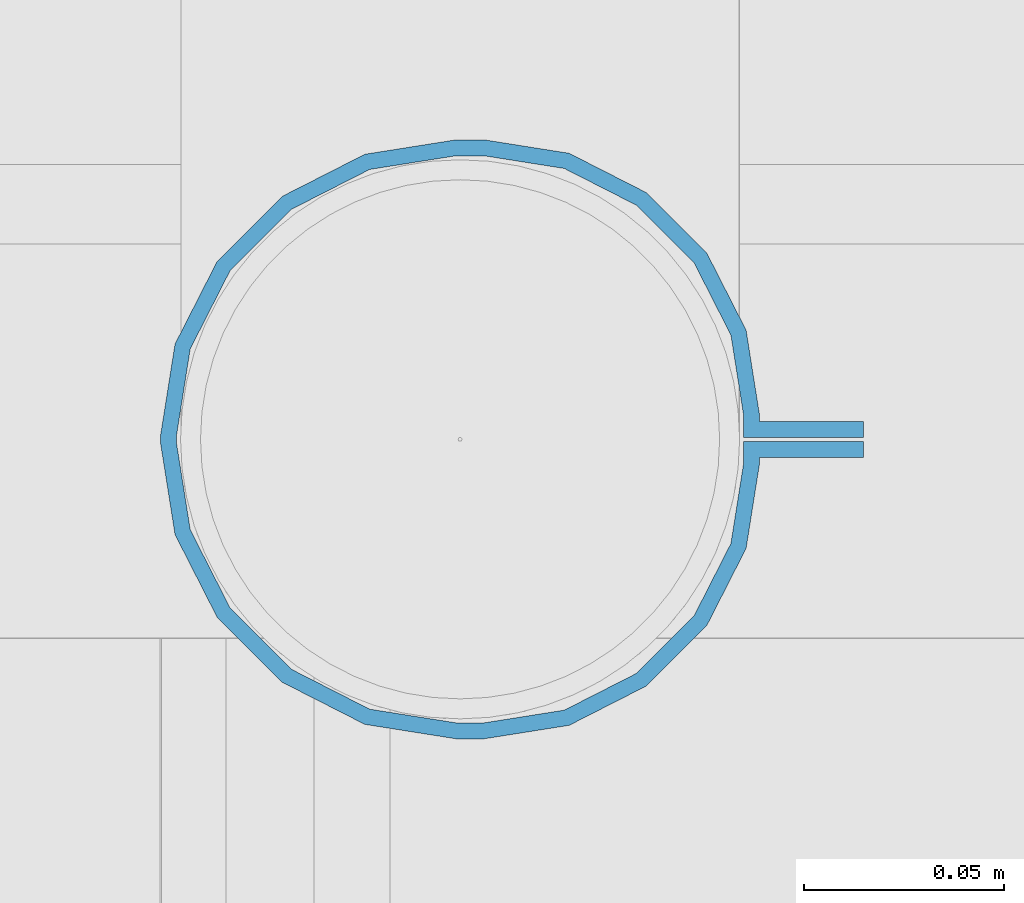
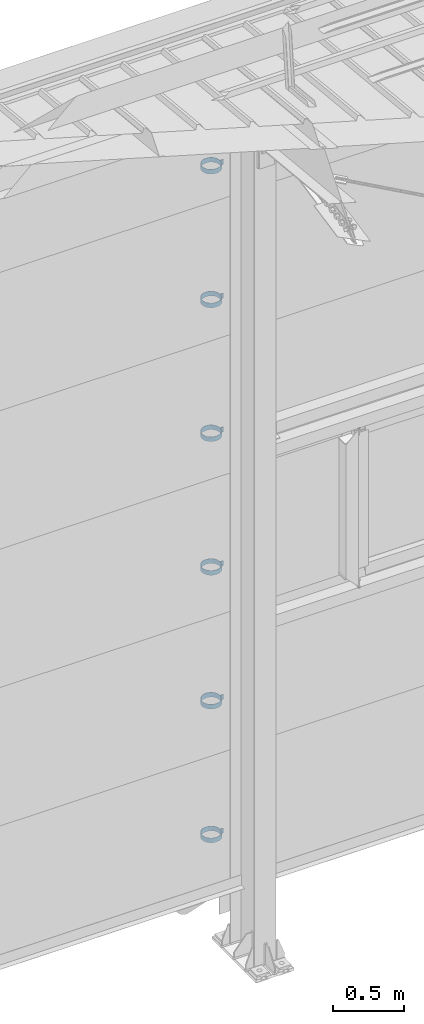
# One storey, part 303 of 709: 6 beams, 6 elements without a shape of their own.
"""IFC4 building model written with IfcOpenShell, lengths in millimetres."""

from ifc_helpers import new_model, si_unit, direction, frame, origin_with_axes, place, context, subcontext, project, spatial, polygons, material, element, aggregate, save


model = new_model("IFC4")

# Units and contexts
model_context = context("Model", 3, precision=0.2, world=origin_with_axes(), true_north=direction((0.0, 1.0)))
body_context = subcontext(model_context, "Body", "Model", "MODEL_VIEW")
ifc_project = project(units=[si_unit("LENGTHUNIT", "METRE", prefix="MILLI"), si_unit("AREAUNIT", "SQUARE_METRE"), si_unit("VOLUMEUNIT", "CUBIC_METRE"), si_unit("MASSUNIT", "GRAM", prefix="KILO"), si_unit("TIMEUNIT", "SECOND"), si_unit("PLANEANGLEUNIT", "RADIAN"), si_unit("SOLIDANGLEUNIT", "STERADIAN"), si_unit("THERMODYNAMICTEMPERATUREUNIT", "DEGREE_CELSIUS"), si_unit("LUMINOUSINTENSITYUNIT", "LUMEN")], contexts=[model_context])

# Site, building, storey
site_placement = place(None, origin_with_axes())
site = spatial("IfcSite", under=ifc_project, at=site_placement, CompositionType="ELEMENT")
building_placement = place(site_placement, origin_with_axes())
building = spatial("IfcBuilding", under=site, at=building_placement, Name="Undefined", CompositionType="ELEMENT")
storey_placement = place(building_placement, origin_with_axes())
storey = spatial("IfcBuildingStorey", under=building, at=storey_placement, Name="Undefined", CompositionType="ELEMENT", Elevation=0.0)

# Assembly, beam
assembly_1_placement = place(storey_placement, frame((4101.0, 22422.5, 6226.92297), z_axis=(0.0, 1.0, 0.0), x_axis=(-1.0, 0.0, 0.0)))
assembly_1 = element("IfcElementAssembly", 1, at=assembly_1_placement, inside=storey)
ifc_material = material(Name="Steel_Undefined", Category="STEEL")
beam_1_placement = place(assembly_1_placement, origin_with_axes())
beam_1 = element("IfcBeam", 2, at=beam_1_placement, material=ifc_material, ObjectType="616", context=body_context, shape_type="Tessellation", body=[
    polygons([(0.0, -20.0, 2.0), (0.0, 20.0, 2.0), (0.0, 20.0, -2.0), (0.0, -20.0, -2.0), (30.0, 20.0, -2.0), (30.0, -20.0, -2.0), (26.0, -20.0, 2.0), (26.0, 20.0, 2.0), (30.0, 20.0, 3.5), (30.0, -20.0, 3.5), (26.0, -20.0, 3.5), (26.0, 20.0, 3.5), (33.18133, 20.0, 23.5861), (33.18133, -20.0, 23.5861), (29.3771, -20.0, 24.82217), (29.3771, 20.0, 24.82217), (39.17783, -20.0, 44.05718), (39.17783, 20.0, 44.05718), (42.4139, 20.0, 41.70604), (42.4139, -20.0, 41.70604), (54.44282, -20.0, 59.32217), (54.44282, 20.0, 59.32217), (56.79396, 20.0, 56.0861), (56.79396, -20.0, 56.0861), (73.67783, -20.0, 69.1229), (73.67783, 20.0, 69.1229), (74.9139, 20.0, 65.31867), (74.9139, -20.0, 65.31867), (95.0, -20.0, 72.5), (95.0, 20.0, 72.5), (95.0, 20.0, 68.5), (95.0, -20.0, 68.5), (102.0, 20.0, 68.5), (102.0, -20.0, 68.5), (102.0, -20.0, 72.5), (102.0, 20.0, 72.5), (123.63119, 20.0, 65.07396), (123.63119, -20.0, 65.07396), (124.86726, -20.0, 68.87818), (124.86726, 20.0, 68.87818), (145.49611, -20.0, 58.36726), (145.49611, 20.0, 58.36726), (143.14497, 20.0, 55.13119), (143.14497, -20.0, 55.13119), (161.86726, -20.0, 41.99611), (161.86726, 20.0, 41.99611), (158.63119, 20.0, 39.64497), (158.63119, -20.0, 39.64497), (172.37818, -20.0, 21.36726), (172.37818, 20.0, 21.36726), (168.57396, 20.0, 20.13119), (168.57396, -20.0, 20.13119), (176.0, -20.0, -1.5), (176.0, 20.0, -1.5), (172.0, 20.0, -1.5), (172.0, -20.0, -1.5), (172.0, 20.0, -3.5), (172.0, -20.0, -3.5), (176.0, -20.0, -3.5), (176.0, 20.0, -3.5), (168.57396, 20.0, -25.13119), (168.57396, -20.0, -25.13119), (172.37818, -20.0, -26.36726), (172.37818, 20.0, -26.36726), (161.86726, -20.0, -46.99611), (161.86726, 20.0, -46.99611), (158.63119, 20.0, -44.64497), (158.63119, -20.0, -44.64497), (145.49611, -20.0, -63.36726), (145.49611, 20.0, -63.36726), (143.14497, 20.0, -60.13119), (143.14497, -20.0, -60.13119), (124.86726, -20.0, -73.87818), (124.86726, 20.0, -73.87818), (123.63119, 20.0, -70.07396), (123.63119, -20.0, -70.07396), (102.0, -20.0, -77.5), (102.0, 20.0, -77.5), (102.0, 20.0, -73.5), (102.0, -20.0, -73.5), (95.0, 20.0, -73.5), (95.0, -20.0, -73.5), (95.0, -20.0, -77.5), (95.0, 20.0, -77.5), (74.9139, 20.0, -70.31867), (74.9139, -20.0, -70.31867), (73.67783, -20.0, -74.1229), (73.67783, 20.0, -74.1229), (54.44282, -20.0, -64.32217), (54.44282, 20.0, -64.32217), (56.79396, 20.0, -61.0861), (56.79396, -20.0, -61.0861), (39.17783, -20.0, -49.05718), (39.17783, 20.0, -49.05718), (42.4139, 20.0, -46.70604), (42.4139, -20.0, -46.70604), (29.3771, -20.0, -29.82217), (29.3771, 20.0, -29.82217), (33.18133, 20.0, -28.5861), (33.18133, -20.0, -28.5861), (26.0, -20.0, -8.5), (26.0, 20.0, -8.5), (30.0, 20.0, -8.5), (30.0, -20.0, -8.5), (30.0, 20.0, -3.0), (30.0, -20.0, -3.0), (26.0, -20.0, -7.0), (26.0, 20.0, -7.0), (0.0, 20.0, -3.0), (0.0, -20.0, -3.0), (0.0, 20.0, -7.0), (0.0, -20.0, -7.0)], [[[1, 2, 3, 4]], [[4, 3, 5, 6]], [[2, 1, 7, 8]], [[6, 5, 9, 10]], [[8, 7, 11, 12]], [[10, 9, 13, 14]], [[12, 11, 15, 16]], [[15, 17, 18, 16]], [[13, 19, 20, 14]], [[17, 21, 22, 18]], [[19, 23, 24, 20]], [[21, 25, 26, 22]], [[23, 27, 28, 24]], [[25, 29, 30, 26]], [[27, 31, 32, 28]], [[32, 31, 33, 34]], [[30, 29, 35, 36]], [[34, 33, 37, 38]], [[36, 35, 39, 40]], [[39, 41, 42, 40]], [[37, 43, 44, 38]], [[41, 45, 46, 42]], [[43, 47, 48, 44]], [[45, 49, 50, 46]], [[47, 51, 52, 48]], [[49, 53, 54, 50]], [[51, 55, 56, 52]], [[56, 55, 57, 58]], [[54, 53, 59, 60]], [[58, 57, 61, 62]], [[60, 59, 63, 64]], [[63, 65, 66, 64]], [[61, 67, 68, 62]], [[65, 69, 70, 66]], [[67, 71, 72, 68]], [[69, 73, 74, 70]], [[71, 75, 76, 72]], [[73, 77, 78, 74]], [[75, 79, 80, 76]], [[80, 79, 81, 82]], [[78, 77, 83, 84]], [[82, 81, 85, 86]], [[84, 83, 87, 88]], [[87, 89, 90, 88]], [[85, 91, 92, 86]], [[89, 93, 94, 90]], [[91, 95, 96, 92]], [[93, 97, 98, 94]], [[95, 99, 100, 96]], [[97, 101, 102, 98]], [[99, 103, 104, 100]], [[104, 103, 105, 106]], [[102, 101, 107, 108]], [[106, 105, 109, 110]], [[105, 103, 99, 95, 91, 85, 81, 79, 75, 71, 67, 61, 57, 55, 51, 47, 43, 37, 33, 31, 27, 23, 19, 13, 9, 5, 3, 2, 8, 12, 16, 18, 22, 26, 30, 36, 40, 42, 46, 50, 54, 60, 64, 66, 70, 74, 78, 84, 88, 90, 94, 98, 102, 108, 111, 109]], [[108, 107, 112, 111]], [[107, 101, 97, 93, 89, 87, 83, 77, 73, 69, 65, 63, 59, 53, 49, 45, 41, 39, 35, 29, 25, 21, 17, 15, 11, 7, 1, 4, 6, 10, 14, 20, 24, 28, 32, 34, 38, 44, 48, 52, 56, 58, 62, 68, 72, 76, 80, 82, 86, 92, 96, 100, 104, 106, 110, 112]], [[111, 112, 110, 109]]], closed=True),
])
aggregate(assembly_1, [beam_1])

assembly_2_placement = place(storey_placement, frame((4101.0, 22422.5, 5076.92297), z_axis=(0.0, 1.0, 0.0), x_axis=(-1.0, 0.0, 0.0)))
assembly_2 = element("IfcElementAssembly", 3, at=assembly_2_placement, inside=storey)
beam_2_placement = place(assembly_2_placement, origin_with_axes())
beam_2 = element("IfcBeam", 4, at=beam_2_placement, material=ifc_material, ObjectType="616", context=body_context, shape_type="Tessellation", body=[
    polygons([(0.0, -20.0, 2.0), (0.0, 20.0, 2.0), (0.0, 20.0, -2.0), (0.0, -20.0, -2.0), (30.0, 20.0, -2.0), (30.0, -20.0, -2.0), (26.0, -20.0, 2.0), (26.0, 20.0, 2.0), (30.0, 20.0, 3.5), (30.0, -20.0, 3.5), (26.0, -20.0, 3.5), (26.0, 20.0, 3.5), (33.18133, 20.0, 23.5861), (33.18133, -20.0, 23.5861), (29.3771, -20.0, 24.82217), (29.3771, 20.0, 24.82217), (39.17783, -20.0, 44.05718), (39.17783, 20.0, 44.05718), (42.4139, 20.0, 41.70604), (42.4139, -20.0, 41.70604), (54.44282, -20.0, 59.32217), (54.44282, 20.0, 59.32217), (56.79396, 20.0, 56.0861), (56.79396, -20.0, 56.0861), (73.67783, -20.0, 69.1229), (73.67783, 20.0, 69.1229), (74.9139, 20.0, 65.31867), (74.9139, -20.0, 65.31867), (95.0, -20.0, 72.5), (95.0, 20.0, 72.5), (95.0, 20.0, 68.5), (95.0, -20.0, 68.5), (102.0, 20.0, 68.5), (102.0, -20.0, 68.5), (102.0, -20.0, 72.5), (102.0, 20.0, 72.5), (123.63119, 20.0, 65.07396), (123.63119, -20.0, 65.07396), (124.86726, -20.0, 68.87818), (124.86726, 20.0, 68.87818), (145.49611, -20.0, 58.36726), (145.49611, 20.0, 58.36726), (143.14497, 20.0, 55.13119), (143.14497, -20.0, 55.13119), (161.86726, -20.0, 41.99611), (161.86726, 20.0, 41.99611), (158.63119, 20.0, 39.64497), (158.63119, -20.0, 39.64497), (172.37818, -20.0, 21.36726), (172.37818, 20.0, 21.36726), (168.57396, 20.0, 20.13119), (168.57396, -20.0, 20.13119), (176.0, -20.0, -1.5), (176.0, 20.0, -1.5), (172.0, 20.0, -1.5), (172.0, -20.0, -1.5), (172.0, 20.0, -3.5), (172.0, -20.0, -3.5), (176.0, -20.0, -3.5), (176.0, 20.0, -3.5), (168.57396, 20.0, -25.13119), (168.57396, -20.0, -25.13119), (172.37818, -20.0, -26.36726), (172.37818, 20.0, -26.36726), (161.86726, -20.0, -46.99611), (161.86726, 20.0, -46.99611), (158.63119, 20.0, -44.64497), (158.63119, -20.0, -44.64497), (145.49611, -20.0, -63.36726), (145.49611, 20.0, -63.36726), (143.14497, 20.0, -60.13119), (143.14497, -20.0, -60.13119), (124.86726, -20.0, -73.87818), (124.86726, 20.0, -73.87818), (123.63119, 20.0, -70.07396), (123.63119, -20.0, -70.07396), (102.0, -20.0, -77.5), (102.0, 20.0, -77.5), (102.0, 20.0, -73.5), (102.0, -20.0, -73.5), (95.0, 20.0, -73.5), (95.0, -20.0, -73.5), (95.0, -20.0, -77.5), (95.0, 20.0, -77.5), (74.9139, 20.0, -70.31867), (74.9139, -20.0, -70.31867), (73.67783, -20.0, -74.1229), (73.67783, 20.0, -74.1229), (54.44282, -20.0, -64.32217), (54.44282, 20.0, -64.32217), (56.79396, 20.0, -61.0861), (56.79396, -20.0, -61.0861), (39.17783, -20.0, -49.05718), (39.17783, 20.0, -49.05718), (42.4139, 20.0, -46.70604), (42.4139, -20.0, -46.70604), (29.3771, -20.0, -29.82217), (29.3771, 20.0, -29.82217), (33.18133, 20.0, -28.5861), (33.18133, -20.0, -28.5861), (26.0, -20.0, -8.5), (26.0, 20.0, -8.5), (30.0, 20.0, -8.5), (30.0, -20.0, -8.5), (30.0, 20.0, -3.0), (30.0, -20.0, -3.0), (26.0, -20.0, -7.0), (26.0, 20.0, -7.0), (0.0, 20.0, -3.0), (0.0, -20.0, -3.0), (0.0, 20.0, -7.0), (0.0, -20.0, -7.0)], [[[1, 2, 3, 4]], [[4, 3, 5, 6]], [[2, 1, 7, 8]], [[6, 5, 9, 10]], [[8, 7, 11, 12]], [[10, 9, 13, 14]], [[12, 11, 15, 16]], [[15, 17, 18, 16]], [[13, 19, 20, 14]], [[17, 21, 22, 18]], [[19, 23, 24, 20]], [[21, 25, 26, 22]], [[23, 27, 28, 24]], [[25, 29, 30, 26]], [[27, 31, 32, 28]], [[32, 31, 33, 34]], [[30, 29, 35, 36]], [[34, 33, 37, 38]], [[36, 35, 39, 40]], [[39, 41, 42, 40]], [[37, 43, 44, 38]], [[41, 45, 46, 42]], [[43, 47, 48, 44]], [[45, 49, 50, 46]], [[47, 51, 52, 48]], [[49, 53, 54, 50]], [[51, 55, 56, 52]], [[56, 55, 57, 58]], [[54, 53, 59, 60]], [[58, 57, 61, 62]], [[60, 59, 63, 64]], [[63, 65, 66, 64]], [[61, 67, 68, 62]], [[65, 69, 70, 66]], [[67, 71, 72, 68]], [[69, 73, 74, 70]], [[71, 75, 76, 72]], [[73, 77, 78, 74]], [[75, 79, 80, 76]], [[80, 79, 81, 82]], [[78, 77, 83, 84]], [[82, 81, 85, 86]], [[84, 83, 87, 88]], [[87, 89, 90, 88]], [[85, 91, 92, 86]], [[89, 93, 94, 90]], [[91, 95, 96, 92]], [[93, 97, 98, 94]], [[95, 99, 100, 96]], [[97, 101, 102, 98]], [[99, 103, 104, 100]], [[104, 103, 105, 106]], [[102, 101, 107, 108]], [[106, 105, 109, 110]], [[105, 103, 99, 95, 91, 85, 81, 79, 75, 71, 67, 61, 57, 55, 51, 47, 43, 37, 33, 31, 27, 23, 19, 13, 9, 5, 3, 2, 8, 12, 16, 18, 22, 26, 30, 36, 40, 42, 46, 50, 54, 60, 64, 66, 70, 74, 78, 84, 88, 90, 94, 98, 102, 108, 111, 109]], [[108, 107, 112, 111]], [[107, 101, 97, 93, 89, 87, 83, 77, 73, 69, 65, 63, 59, 53, 49, 45, 41, 39, 35, 29, 25, 21, 17, 15, 11, 7, 1, 4, 6, 10, 14, 20, 24, 28, 32, 34, 38, 44, 48, 52, 56, 58, 62, 68, 72, 76, 80, 82, 86, 92, 96, 100, 104, 106, 110, 112]], [[111, 112, 110, 109]]], closed=True),
])
aggregate(assembly_2, [beam_2])

assembly_3_placement = place(storey_placement, frame((4101.0, 22422.5, 3926.92297), z_axis=(0.0, 1.0, 0.0), x_axis=(-1.0, 0.0, 0.0)))
assembly_3 = element("IfcElementAssembly", 5, at=assembly_3_placement, inside=storey)
beam_3_placement = place(assembly_3_placement, origin_with_axes())
beam_3 = element("IfcBeam", 6, at=beam_3_placement, material=ifc_material, ObjectType="616", context=body_context, shape_type="Tessellation", body=[
    polygons([(0.0, -20.0, 2.0), (0.0, 20.0, 2.0), (0.0, 20.0, -2.0), (0.0, -20.0, -2.0), (30.0, 20.0, -2.0), (30.0, -20.0, -2.0), (26.0, -20.0, 2.0), (26.0, 20.0, 2.0), (30.0, 20.0, 3.5), (30.0, -20.0, 3.5), (26.0, -20.0, 3.5), (26.0, 20.0, 3.5), (33.18133, 20.0, 23.5861), (33.18133, -20.0, 23.5861), (29.3771, -20.0, 24.82217), (29.3771, 20.0, 24.82217), (39.17783, -20.0, 44.05718), (39.17783, 20.0, 44.05718), (42.4139, 20.0, 41.70604), (42.4139, -20.0, 41.70604), (54.44282, -20.0, 59.32217), (54.44282, 20.0, 59.32217), (56.79396, 20.0, 56.0861), (56.79396, -20.0, 56.0861), (73.67783, -20.0, 69.1229), (73.67783, 20.0, 69.1229), (74.9139, 20.0, 65.31867), (74.9139, -20.0, 65.31867), (95.0, -20.0, 72.5), (95.0, 20.0, 72.5), (95.0, 20.0, 68.5), (95.0, -20.0, 68.5), (102.0, 20.0, 68.5), (102.0, -20.0, 68.5), (102.0, -20.0, 72.5), (102.0, 20.0, 72.5), (123.63119, 20.0, 65.07396), (123.63119, -20.0, 65.07396), (124.86726, -20.0, 68.87818), (124.86726, 20.0, 68.87818), (145.49611, -20.0, 58.36726), (145.49611, 20.0, 58.36726), (143.14497, 20.0, 55.13119), (143.14497, -20.0, 55.13119), (161.86726, -20.0, 41.99611), (161.86726, 20.0, 41.99611), (158.63119, 20.0, 39.64497), (158.63119, -20.0, 39.64497), (172.37818, -20.0, 21.36726), (172.37818, 20.0, 21.36726), (168.57396, 20.0, 20.13119), (168.57396, -20.0, 20.13119), (176.0, -20.0, -1.5), (176.0, 20.0, -1.5), (172.0, 20.0, -1.5), (172.0, -20.0, -1.5), (172.0, 20.0, -3.5), (172.0, -20.0, -3.5), (176.0, -20.0, -3.5), (176.0, 20.0, -3.5), (168.57396, 20.0, -25.13119), (168.57396, -20.0, -25.13119), (172.37818, -20.0, -26.36726), (172.37818, 20.0, -26.36726), (161.86726, -20.0, -46.99611), (161.86726, 20.0, -46.99611), (158.63119, 20.0, -44.64497), (158.63119, -20.0, -44.64497), (145.49611, -20.0, -63.36726), (145.49611, 20.0, -63.36726), (143.14497, 20.0, -60.13119), (143.14497, -20.0, -60.13119), (124.86726, -20.0, -73.87818), (124.86726, 20.0, -73.87818), (123.63119, 20.0, -70.07396), (123.63119, -20.0, -70.07396), (102.0, -20.0, -77.5), (102.0, 20.0, -77.5), (102.0, 20.0, -73.5), (102.0, -20.0, -73.5), (95.0, 20.0, -73.5), (95.0, -20.0, -73.5), (95.0, -20.0, -77.5), (95.0, 20.0, -77.5), (74.9139, 20.0, -70.31867), (74.9139, -20.0, -70.31867), (73.67783, -20.0, -74.1229), (73.67783, 20.0, -74.1229), (54.44282, -20.0, -64.32217), (54.44282, 20.0, -64.32217), (56.79396, 20.0, -61.0861), (56.79396, -20.0, -61.0861), (39.17783, -20.0, -49.05718), (39.17783, 20.0, -49.05718), (42.4139, 20.0, -46.70604), (42.4139, -20.0, -46.70604), (29.3771, -20.0, -29.82217), (29.3771, 20.0, -29.82217), (33.18133, 20.0, -28.5861), (33.18133, -20.0, -28.5861), (26.0, -20.0, -8.5), (26.0, 20.0, -8.5), (30.0, 20.0, -8.5), (30.0, -20.0, -8.5), (30.0, 20.0, -3.0), (30.0, -20.0, -3.0), (26.0, -20.0, -7.0), (26.0, 20.0, -7.0), (0.0, 20.0, -3.0), (0.0, -20.0, -3.0), (0.0, 20.0, -7.0), (0.0, -20.0, -7.0)], [[[1, 2, 3, 4]], [[4, 3, 5, 6]], [[2, 1, 7, 8]], [[6, 5, 9, 10]], [[8, 7, 11, 12]], [[10, 9, 13, 14]], [[12, 11, 15, 16]], [[15, 17, 18, 16]], [[13, 19, 20, 14]], [[17, 21, 22, 18]], [[19, 23, 24, 20]], [[21, 25, 26, 22]], [[23, 27, 28, 24]], [[25, 29, 30, 26]], [[27, 31, 32, 28]], [[32, 31, 33, 34]], [[30, 29, 35, 36]], [[34, 33, 37, 38]], [[36, 35, 39, 40]], [[39, 41, 42, 40]], [[37, 43, 44, 38]], [[41, 45, 46, 42]], [[43, 47, 48, 44]], [[45, 49, 50, 46]], [[47, 51, 52, 48]], [[49, 53, 54, 50]], [[51, 55, 56, 52]], [[56, 55, 57, 58]], [[54, 53, 59, 60]], [[58, 57, 61, 62]], [[60, 59, 63, 64]], [[63, 65, 66, 64]], [[61, 67, 68, 62]], [[65, 69, 70, 66]], [[67, 71, 72, 68]], [[69, 73, 74, 70]], [[71, 75, 76, 72]], [[73, 77, 78, 74]], [[75, 79, 80, 76]], [[80, 79, 81, 82]], [[78, 77, 83, 84]], [[82, 81, 85, 86]], [[84, 83, 87, 88]], [[87, 89, 90, 88]], [[85, 91, 92, 86]], [[89, 93, 94, 90]], [[91, 95, 96, 92]], [[93, 97, 98, 94]], [[95, 99, 100, 96]], [[97, 101, 102, 98]], [[99, 103, 104, 100]], [[104, 103, 105, 106]], [[102, 101, 107, 108]], [[106, 105, 109, 110]], [[105, 103, 99, 95, 91, 85, 81, 79, 75, 71, 67, 61, 57, 55, 51, 47, 43, 37, 33, 31, 27, 23, 19, 13, 9, 5, 3, 2, 8, 12, 16, 18, 22, 26, 30, 36, 40, 42, 46, 50, 54, 60, 64, 66, 70, 74, 78, 84, 88, 90, 94, 98, 102, 108, 111, 109]], [[108, 107, 112, 111]], [[107, 101, 97, 93, 89, 87, 83, 77, 73, 69, 65, 63, 59, 53, 49, 45, 41, 39, 35, 29, 25, 21, 17, 15, 11, 7, 1, 4, 6, 10, 14, 20, 24, 28, 32, 34, 38, 44, 48, 52, 56, 58, 62, 68, 72, 76, 80, 82, 86, 92, 96, 100, 104, 106, 110, 112]], [[111, 112, 110, 109]]], closed=True),
])
aggregate(assembly_3, [beam_3])

assembly_4_placement = place(storey_placement, frame((4101.0, 22422.5, 2776.92297), z_axis=(0.0, 1.0, 0.0), x_axis=(-1.0, 0.0, 0.0)))
assembly_4 = element("IfcElementAssembly", 7, at=assembly_4_placement, inside=storey)
beam_4_placement = place(assembly_4_placement, origin_with_axes())
beam_4 = element("IfcBeam", 8, at=beam_4_placement, material=ifc_material, ObjectType="616", context=body_context, shape_type="Tessellation", body=[
    polygons([(0.0, -20.0, 2.0), (0.0, 20.0, 2.0), (0.0, 20.0, -2.0), (0.0, -20.0, -2.0), (30.0, 20.0, -2.0), (30.0, -20.0, -2.0), (26.0, -20.0, 2.0), (26.0, 20.0, 2.0), (30.0, 20.0, 3.5), (30.0, -20.0, 3.5), (26.0, -20.0, 3.5), (26.0, 20.0, 3.5), (33.18133, 20.0, 23.5861), (33.18133, -20.0, 23.5861), (29.3771, -20.0, 24.82217), (29.3771, 20.0, 24.82217), (39.17783, -20.0, 44.05718), (39.17783, 20.0, 44.05718), (42.4139, 20.0, 41.70604), (42.4139, -20.0, 41.70604), (54.44282, -20.0, 59.32217), (54.44282, 20.0, 59.32217), (56.79396, 20.0, 56.0861), (56.79396, -20.0, 56.0861), (73.67783, -20.0, 69.1229), (73.67783, 20.0, 69.1229), (74.9139, 20.0, 65.31867), (74.9139, -20.0, 65.31867), (95.0, -20.0, 72.5), (95.0, 20.0, 72.5), (95.0, 20.0, 68.5), (95.0, -20.0, 68.5), (102.0, 20.0, 68.5), (102.0, -20.0, 68.5), (102.0, -20.0, 72.5), (102.0, 20.0, 72.5), (123.63119, 20.0, 65.07396), (123.63119, -20.0, 65.07396), (124.86726, -20.0, 68.87818), (124.86726, 20.0, 68.87818), (145.49611, -20.0, 58.36726), (145.49611, 20.0, 58.36726), (143.14497, 20.0, 55.13119), (143.14497, -20.0, 55.13119), (161.86726, -20.0, 41.99611), (161.86726, 20.0, 41.99611), (158.63119, 20.0, 39.64497), (158.63119, -20.0, 39.64497), (172.37818, -20.0, 21.36726), (172.37818, 20.0, 21.36726), (168.57396, 20.0, 20.13119), (168.57396, -20.0, 20.13119), (176.0, -20.0, -1.5), (176.0, 20.0, -1.5), (172.0, 20.0, -1.5), (172.0, -20.0, -1.5), (172.0, 20.0, -3.5), (172.0, -20.0, -3.5), (176.0, -20.0, -3.5), (176.0, 20.0, -3.5), (168.57396, 20.0, -25.13119), (168.57396, -20.0, -25.13119), (172.37818, -20.0, -26.36726), (172.37818, 20.0, -26.36726), (161.86726, -20.0, -46.99611), (161.86726, 20.0, -46.99611), (158.63119, 20.0, -44.64497), (158.63119, -20.0, -44.64497), (145.49611, -20.0, -63.36726), (145.49611, 20.0, -63.36726), (143.14497, 20.0, -60.13119), (143.14497, -20.0, -60.13119), (124.86726, -20.0, -73.87818), (124.86726, 20.0, -73.87818), (123.63119, 20.0, -70.07396), (123.63119, -20.0, -70.07396), (102.0, -20.0, -77.5), (102.0, 20.0, -77.5), (102.0, 20.0, -73.5), (102.0, -20.0, -73.5), (95.0, 20.0, -73.5), (95.0, -20.0, -73.5), (95.0, -20.0, -77.5), (95.0, 20.0, -77.5), (74.9139, 20.0, -70.31867), (74.9139, -20.0, -70.31867), (73.67783, -20.0, -74.1229), (73.67783, 20.0, -74.1229), (54.44282, -20.0, -64.32217), (54.44282, 20.0, -64.32217), (56.79396, 20.0, -61.0861), (56.79396, -20.0, -61.0861), (39.17783, -20.0, -49.05718), (39.17783, 20.0, -49.05718), (42.4139, 20.0, -46.70604), (42.4139, -20.0, -46.70604), (29.3771, -20.0, -29.82217), (29.3771, 20.0, -29.82217), (33.18133, 20.0, -28.5861), (33.18133, -20.0, -28.5861), (26.0, -20.0, -8.5), (26.0, 20.0, -8.5), (30.0, 20.0, -8.5), (30.0, -20.0, -8.5), (30.0, 20.0, -3.0), (30.0, -20.0, -3.0), (26.0, -20.0, -7.0), (26.0, 20.0, -7.0), (0.0, 20.0, -3.0), (0.0, -20.0, -3.0), (0.0, 20.0, -7.0), (0.0, -20.0, -7.0)], [[[1, 2, 3, 4]], [[4, 3, 5, 6]], [[2, 1, 7, 8]], [[6, 5, 9, 10]], [[8, 7, 11, 12]], [[10, 9, 13, 14]], [[12, 11, 15, 16]], [[15, 17, 18, 16]], [[13, 19, 20, 14]], [[17, 21, 22, 18]], [[19, 23, 24, 20]], [[21, 25, 26, 22]], [[23, 27, 28, 24]], [[25, 29, 30, 26]], [[27, 31, 32, 28]], [[32, 31, 33, 34]], [[30, 29, 35, 36]], [[34, 33, 37, 38]], [[36, 35, 39, 40]], [[39, 41, 42, 40]], [[37, 43, 44, 38]], [[41, 45, 46, 42]], [[43, 47, 48, 44]], [[45, 49, 50, 46]], [[47, 51, 52, 48]], [[49, 53, 54, 50]], [[51, 55, 56, 52]], [[56, 55, 57, 58]], [[54, 53, 59, 60]], [[58, 57, 61, 62]], [[60, 59, 63, 64]], [[63, 65, 66, 64]], [[61, 67, 68, 62]], [[65, 69, 70, 66]], [[67, 71, 72, 68]], [[69, 73, 74, 70]], [[71, 75, 76, 72]], [[73, 77, 78, 74]], [[75, 79, 80, 76]], [[80, 79, 81, 82]], [[78, 77, 83, 84]], [[82, 81, 85, 86]], [[84, 83, 87, 88]], [[87, 89, 90, 88]], [[85, 91, 92, 86]], [[89, 93, 94, 90]], [[91, 95, 96, 92]], [[93, 97, 98, 94]], [[95, 99, 100, 96]], [[97, 101, 102, 98]], [[99, 103, 104, 100]], [[104, 103, 105, 106]], [[102, 101, 107, 108]], [[106, 105, 109, 110]], [[105, 103, 99, 95, 91, 85, 81, 79, 75, 71, 67, 61, 57, 55, 51, 47, 43, 37, 33, 31, 27, 23, 19, 13, 9, 5, 3, 2, 8, 12, 16, 18, 22, 26, 30, 36, 40, 42, 46, 50, 54, 60, 64, 66, 70, 74, 78, 84, 88, 90, 94, 98, 102, 108, 111, 109]], [[108, 107, 112, 111]], [[107, 101, 97, 93, 89, 87, 83, 77, 73, 69, 65, 63, 59, 53, 49, 45, 41, 39, 35, 29, 25, 21, 17, 15, 11, 7, 1, 4, 6, 10, 14, 20, 24, 28, 32, 34, 38, 44, 48, 52, 56, 58, 62, 68, 72, 76, 80, 82, 86, 92, 96, 100, 104, 106, 110, 112]], [[111, 112, 110, 109]]], closed=True),
])
aggregate(assembly_4, [beam_4])

assembly_5_placement = place(storey_placement, frame((4101.0, 22422.5, 1626.92297), z_axis=(0.0, 1.0, 0.0), x_axis=(-1.0, 0.0, 0.0)))
assembly_5 = element("IfcElementAssembly", 9, at=assembly_5_placement, inside=storey)
beam_5_placement = place(assembly_5_placement, origin_with_axes())
beam_5 = element("IfcBeam", 10, at=beam_5_placement, material=ifc_material, ObjectType="616", context=body_context, shape_type="Tessellation", body=[
    polygons([(0.0, -20.0, 2.0), (0.0, 20.0, 2.0), (0.0, 20.0, -2.0), (0.0, -20.0, -2.0), (30.0, 20.0, -2.0), (30.0, -20.0, -2.0), (26.0, -20.0, 2.0), (26.0, 20.0, 2.0), (30.0, 20.0, 3.5), (30.0, -20.0, 3.5), (26.0, -20.0, 3.5), (26.0, 20.0, 3.5), (33.18133, 20.0, 23.5861), (33.18133, -20.0, 23.5861), (29.3771, -20.0, 24.82217), (29.3771, 20.0, 24.82217), (39.17783, -20.0, 44.05718), (39.17783, 20.0, 44.05718), (42.4139, 20.0, 41.70604), (42.4139, -20.0, 41.70604), (54.44282, -20.0, 59.32217), (54.44282, 20.0, 59.32217), (56.79396, 20.0, 56.0861), (56.79396, -20.0, 56.0861), (73.67783, -20.0, 69.1229), (73.67783, 20.0, 69.1229), (74.9139, 20.0, 65.31867), (74.9139, -20.0, 65.31867), (95.0, -20.0, 72.5), (95.0, 20.0, 72.5), (95.0, 20.0, 68.5), (95.0, -20.0, 68.5), (102.0, 20.0, 68.5), (102.0, -20.0, 68.5), (102.0, -20.0, 72.5), (102.0, 20.0, 72.5), (123.63119, 20.0, 65.07396), (123.63119, -20.0, 65.07396), (124.86726, -20.0, 68.87818), (124.86726, 20.0, 68.87818), (145.49611, -20.0, 58.36726), (145.49611, 20.0, 58.36726), (143.14497, 20.0, 55.13119), (143.14497, -20.0, 55.13119), (161.86726, -20.0, 41.99611), (161.86726, 20.0, 41.99611), (158.63119, 20.0, 39.64497), (158.63119, -20.0, 39.64497), (172.37818, -20.0, 21.36726), (172.37818, 20.0, 21.36726), (168.57396, 20.0, 20.13119), (168.57396, -20.0, 20.13119), (176.0, -20.0, -1.5), (176.0, 20.0, -1.5), (172.0, 20.0, -1.5), (172.0, -20.0, -1.5), (172.0, 20.0, -3.5), (172.0, -20.0, -3.5), (176.0, -20.0, -3.5), (176.0, 20.0, -3.5), (168.57396, 20.0, -25.13119), (168.57396, -20.0, -25.13119), (172.37818, -20.0, -26.36726), (172.37818, 20.0, -26.36726), (161.86726, -20.0, -46.99611), (161.86726, 20.0, -46.99611), (158.63119, 20.0, -44.64497), (158.63119, -20.0, -44.64497), (145.49611, -20.0, -63.36726), (145.49611, 20.0, -63.36726), (143.14497, 20.0, -60.13119), (143.14497, -20.0, -60.13119), (124.86726, -20.0, -73.87818), (124.86726, 20.0, -73.87818), (123.63119, 20.0, -70.07396), (123.63119, -20.0, -70.07396), (102.0, -20.0, -77.5), (102.0, 20.0, -77.5), (102.0, 20.0, -73.5), (102.0, -20.0, -73.5), (95.0, 20.0, -73.5), (95.0, -20.0, -73.5), (95.0, -20.0, -77.5), (95.0, 20.0, -77.5), (74.9139, 20.0, -70.31867), (74.9139, -20.0, -70.31867), (73.67783, -20.0, -74.1229), (73.67783, 20.0, -74.1229), (54.44282, -20.0, -64.32217), (54.44282, 20.0, -64.32217), (56.79396, 20.0, -61.0861), (56.79396, -20.0, -61.0861), (39.17783, -20.0, -49.05718), (39.17783, 20.0, -49.05718), (42.4139, 20.0, -46.70604), (42.4139, -20.0, -46.70604), (29.3771, -20.0, -29.82217), (29.3771, 20.0, -29.82217), (33.18133, 20.0, -28.5861), (33.18133, -20.0, -28.5861), (26.0, -20.0, -8.5), (26.0, 20.0, -8.5), (30.0, 20.0, -8.5), (30.0, -20.0, -8.5), (30.0, 20.0, -3.0), (30.0, -20.0, -3.0), (26.0, -20.0, -7.0), (26.0, 20.0, -7.0), (0.0, 20.0, -3.0), (0.0, -20.0, -3.0), (0.0, 20.0, -7.0), (0.0, -20.0, -7.0)], [[[1, 2, 3, 4]], [[4, 3, 5, 6]], [[2, 1, 7, 8]], [[6, 5, 9, 10]], [[8, 7, 11, 12]], [[10, 9, 13, 14]], [[12, 11, 15, 16]], [[15, 17, 18, 16]], [[13, 19, 20, 14]], [[17, 21, 22, 18]], [[19, 23, 24, 20]], [[21, 25, 26, 22]], [[23, 27, 28, 24]], [[25, 29, 30, 26]], [[27, 31, 32, 28]], [[32, 31, 33, 34]], [[30, 29, 35, 36]], [[34, 33, 37, 38]], [[36, 35, 39, 40]], [[39, 41, 42, 40]], [[37, 43, 44, 38]], [[41, 45, 46, 42]], [[43, 47, 48, 44]], [[45, 49, 50, 46]], [[47, 51, 52, 48]], [[49, 53, 54, 50]], [[51, 55, 56, 52]], [[56, 55, 57, 58]], [[54, 53, 59, 60]], [[58, 57, 61, 62]], [[60, 59, 63, 64]], [[63, 65, 66, 64]], [[61, 67, 68, 62]], [[65, 69, 70, 66]], [[67, 71, 72, 68]], [[69, 73, 74, 70]], [[71, 75, 76, 72]], [[73, 77, 78, 74]], [[75, 79, 80, 76]], [[80, 79, 81, 82]], [[78, 77, 83, 84]], [[82, 81, 85, 86]], [[84, 83, 87, 88]], [[87, 89, 90, 88]], [[85, 91, 92, 86]], [[89, 93, 94, 90]], [[91, 95, 96, 92]], [[93, 97, 98, 94]], [[95, 99, 100, 96]], [[97, 101, 102, 98]], [[99, 103, 104, 100]], [[104, 103, 105, 106]], [[102, 101, 107, 108]], [[106, 105, 109, 110]], [[105, 103, 99, 95, 91, 85, 81, 79, 75, 71, 67, 61, 57, 55, 51, 47, 43, 37, 33, 31, 27, 23, 19, 13, 9, 5, 3, 2, 8, 12, 16, 18, 22, 26, 30, 36, 40, 42, 46, 50, 54, 60, 64, 66, 70, 74, 78, 84, 88, 90, 94, 98, 102, 108, 111, 109]], [[108, 107, 112, 111]], [[107, 101, 97, 93, 89, 87, 83, 77, 73, 69, 65, 63, 59, 53, 49, 45, 41, 39, 35, 29, 25, 21, 17, 15, 11, 7, 1, 4, 6, 10, 14, 20, 24, 28, 32, 34, 38, 44, 48, 52, 56, 58, 62, 68, 72, 76, 80, 82, 86, 92, 96, 100, 104, 106, 110, 112]], [[111, 112, 110, 109]]], closed=True),
])
aggregate(assembly_5, [beam_5])

assembly_6_placement = place(storey_placement, frame((4101.0, 22422.5, 476.92297), z_axis=(0.0, 1.0, 0.0), x_axis=(-1.0, 0.0, 0.0)))
assembly_6 = element("IfcElementAssembly", 11, at=assembly_6_placement, inside=storey)
beam_6_placement = place(assembly_6_placement, origin_with_axes())
beam_6 = element("IfcBeam", 12, at=beam_6_placement, material=ifc_material, ObjectType="616", context=body_context, shape_type="Tessellation", body=[
    polygons([(0.0, -20.0, 2.0), (0.0, 20.0, 2.0), (0.0, 20.0, -2.0), (0.0, -20.0, -2.0), (30.0, 20.0, -2.0), (30.0, -20.0, -2.0), (26.0, -20.0, 2.0), (26.0, 20.0, 2.0), (30.0, 20.0, 3.5), (30.0, -20.0, 3.5), (26.0, -20.0, 3.5), (26.0, 20.0, 3.5), (33.18133, 20.0, 23.5861), (33.18133, -20.0, 23.5861), (29.3771, -20.0, 24.82217), (29.3771, 20.0, 24.82217), (39.17783, -20.0, 44.05718), (39.17783, 20.0, 44.05718), (42.4139, 20.0, 41.70604), (42.4139, -20.0, 41.70604), (54.44282, -20.0, 59.32217), (54.44282, 20.0, 59.32217), (56.79396, 20.0, 56.0861), (56.79396, -20.0, 56.0861), (73.67783, -20.0, 69.1229), (73.67783, 20.0, 69.1229), (74.9139, 20.0, 65.31867), (74.9139, -20.0, 65.31867), (95.0, -20.0, 72.5), (95.0, 20.0, 72.5), (95.0, 20.0, 68.5), (95.0, -20.0, 68.5), (102.0, 20.0, 68.5), (102.0, -20.0, 68.5), (102.0, -20.0, 72.5), (102.0, 20.0, 72.5), (123.63119, 20.0, 65.07396), (123.63119, -20.0, 65.07396), (124.86726, -20.0, 68.87818), (124.86726, 20.0, 68.87818), (145.49611, -20.0, 58.36726), (145.49611, 20.0, 58.36726), (143.14497, 20.0, 55.13119), (143.14497, -20.0, 55.13119), (161.86726, -20.0, 41.99611), (161.86726, 20.0, 41.99611), (158.63119, 20.0, 39.64497), (158.63119, -20.0, 39.64497), (172.37818, -20.0, 21.36726), (172.37818, 20.0, 21.36726), (168.57396, 20.0, 20.13119), (168.57396, -20.0, 20.13119), (176.0, -20.0, -1.5), (176.0, 20.0, -1.5), (172.0, 20.0, -1.5), (172.0, -20.0, -1.5), (172.0, 20.0, -3.5), (172.0, -20.0, -3.5), (176.0, -20.0, -3.5), (176.0, 20.0, -3.5), (168.57396, 20.0, -25.13119), (168.57396, -20.0, -25.13119), (172.37818, -20.0, -26.36726), (172.37818, 20.0, -26.36726), (161.86726, -20.0, -46.99611), (161.86726, 20.0, -46.99611), (158.63119, 20.0, -44.64497), (158.63119, -20.0, -44.64497), (145.49611, -20.0, -63.36726), (145.49611, 20.0, -63.36726), (143.14497, 20.0, -60.13119), (143.14497, -20.0, -60.13119), (124.86726, -20.0, -73.87818), (124.86726, 20.0, -73.87818), (123.63119, 20.0, -70.07396), (123.63119, -20.0, -70.07396), (102.0, -20.0, -77.5), (102.0, 20.0, -77.5), (102.0, 20.0, -73.5), (102.0, -20.0, -73.5), (95.0, 20.0, -73.5), (95.0, -20.0, -73.5), (95.0, -20.0, -77.5), (95.0, 20.0, -77.5), (74.9139, 20.0, -70.31867), (74.9139, -20.0, -70.31867), (73.67783, -20.0, -74.1229), (73.67783, 20.0, -74.1229), (54.44282, -20.0, -64.32217), (54.44282, 20.0, -64.32217), (56.79396, 20.0, -61.0861), (56.79396, -20.0, -61.0861), (39.17783, -20.0, -49.05718), (39.17783, 20.0, -49.05718), (42.4139, 20.0, -46.70604), (42.4139, -20.0, -46.70604), (29.3771, -20.0, -29.82217), (29.3771, 20.0, -29.82217), (33.18133, 20.0, -28.5861), (33.18133, -20.0, -28.5861), (26.0, -20.0, -8.5), (26.0, 20.0, -8.5), (30.0, 20.0, -8.5), (30.0, -20.0, -8.5), (30.0, 20.0, -3.0), (30.0, -20.0, -3.0), (26.0, -20.0, -7.0), (26.0, 20.0, -7.0), (0.0, 20.0, -3.0), (0.0, -20.0, -3.0), (0.0, 20.0, -7.0), (0.0, -20.0, -7.0)], [[[1, 2, 3, 4]], [[4, 3, 5, 6]], [[2, 1, 7, 8]], [[6, 5, 9, 10]], [[8, 7, 11, 12]], [[10, 9, 13, 14]], [[12, 11, 15, 16]], [[15, 17, 18, 16]], [[13, 19, 20, 14]], [[17, 21, 22, 18]], [[19, 23, 24, 20]], [[21, 25, 26, 22]], [[23, 27, 28, 24]], [[25, 29, 30, 26]], [[27, 31, 32, 28]], [[32, 31, 33, 34]], [[30, 29, 35, 36]], [[34, 33, 37, 38]], [[36, 35, 39, 40]], [[39, 41, 42, 40]], [[37, 43, 44, 38]], [[41, 45, 46, 42]], [[43, 47, 48, 44]], [[45, 49, 50, 46]], [[47, 51, 52, 48]], [[49, 53, 54, 50]], [[51, 55, 56, 52]], [[56, 55, 57, 58]], [[54, 53, 59, 60]], [[58, 57, 61, 62]], [[60, 59, 63, 64]], [[63, 65, 66, 64]], [[61, 67, 68, 62]], [[65, 69, 70, 66]], [[67, 71, 72, 68]], [[69, 73, 74, 70]], [[71, 75, 76, 72]], [[73, 77, 78, 74]], [[75, 79, 80, 76]], [[80, 79, 81, 82]], [[78, 77, 83, 84]], [[82, 81, 85, 86]], [[84, 83, 87, 88]], [[87, 89, 90, 88]], [[85, 91, 92, 86]], [[89, 93, 94, 90]], [[91, 95, 96, 92]], [[93, 97, 98, 94]], [[95, 99, 100, 96]], [[97, 101, 102, 98]], [[99, 103, 104, 100]], [[104, 103, 105, 106]], [[102, 101, 107, 108]], [[106, 105, 109, 110]], [[105, 103, 99, 95, 91, 85, 81, 79, 75, 71, 67, 61, 57, 55, 51, 47, 43, 37, 33, 31, 27, 23, 19, 13, 9, 5, 3, 2, 8, 12, 16, 18, 22, 26, 30, 36, 40, 42, 46, 50, 54, 60, 64, 66, 70, 74, 78, 84, 88, 90, 94, 98, 102, 108, 111, 109]], [[108, 107, 112, 111]], [[107, 101, 97, 93, 89, 87, 83, 77, 73, 69, 65, 63, 59, 53, 49, 45, 41, 39, 35, 29, 25, 21, 17, 15, 11, 7, 1, 4, 6, 10, 14, 20, 24, 28, 32, 34, 38, 44, 48, 52, 56, 58, 62, 68, 72, 76, 80, 82, 86, 92, 96, 100, 104, 106, 110, 112]], [[111, 112, 110, 109]]], closed=True),
])
aggregate(assembly_6, [beam_6])

save(model, "model.ifc")
